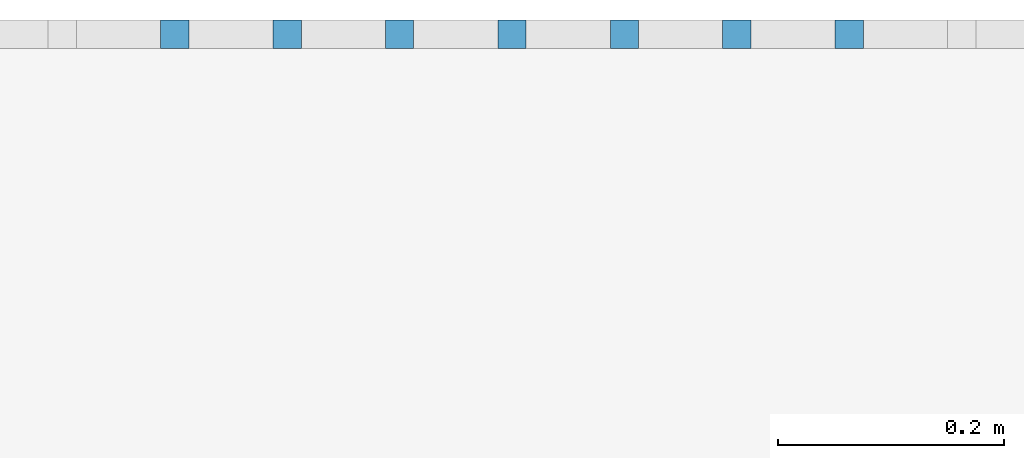
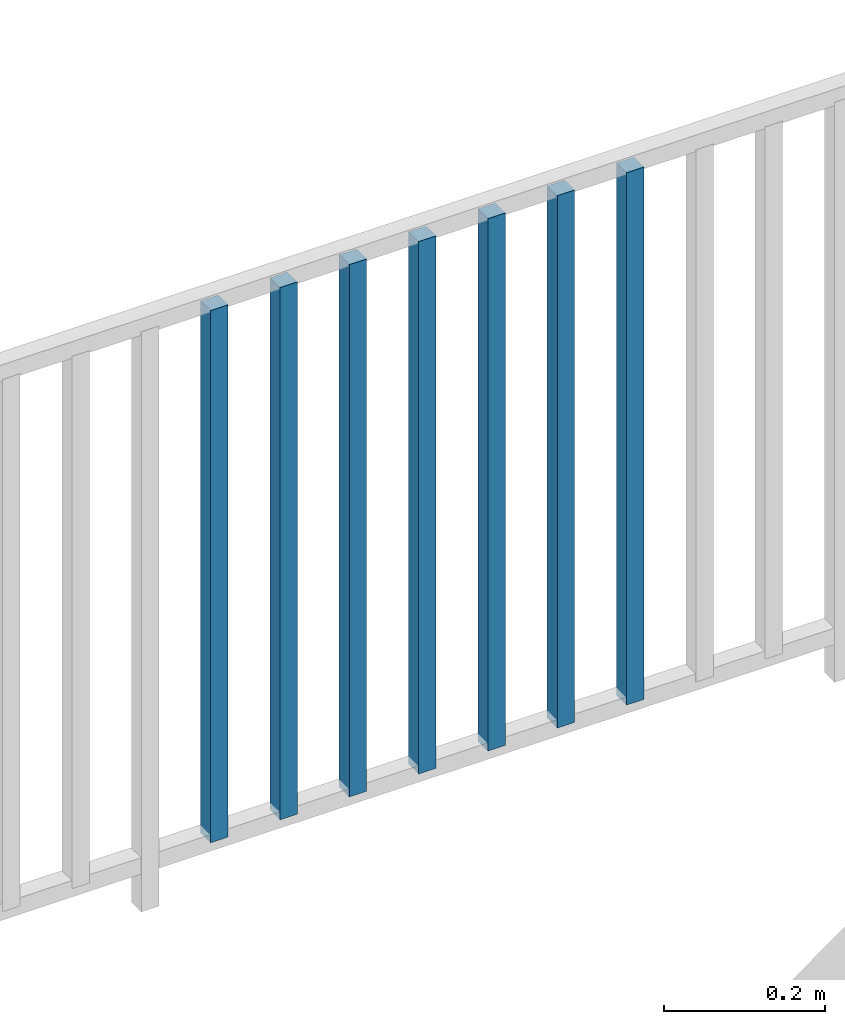
# One storey, part 45 of 48: 7 building element parts, 1 element without a shape of its own.
"""IFC4 building model written with IfcOpenShell, lengths in metres."""

from ifc_helpers import new_model, entity, si_unit, converted_unit, derived_unit, direction, frame, origin_with_axes, place, context, subcontext, project, spatial, polygons, material, type_object, element, aggregate, save


model = new_model("IFC4")

# Units and contexts
model_context = context("Model", 3, precision=1e-05, world=origin_with_axes(), true_north=direction((0.0, 1.0)))
body_context = subcontext(model_context, "Body", "Model", "MODEL_VIEW")
ifc_project = project(units=[si_unit("LENGTHUNIT", "METRE"), si_unit("AREAUNIT", "SQUARE_METRE"), si_unit("VOLUMEUNIT", "CUBIC_METRE"), converted_unit("PLANEANGLEUNIT", "DEGREE", entity("IfcPlaneAngleMeasure", 0.0174532925199), si_unit("PLANEANGLEUNIT", "RADIAN"), dimensions=[0, 0, 0, 0, 0, 0, 0]), converted_unit("TIMEUNIT", "Year", entity("IfcTimeMeasure", 31556926.0), si_unit("TIMEUNIT", "SECOND"), dimensions=[0, 0, 1, 0, 0, 0, 0]), si_unit("MASSUNIT", "GRAM", prefix="KILO"), si_unit("THERMODYNAMICTEMPERATUREUNIT", "DEGREE_CELSIUS"), si_unit("LUMINOUSINTENSITYUNIT", "LUMEN"), si_unit("ENERGYUNIT", "JOULE", prefix="MEGA"), derived_unit("THERMALCONDUCTANCEUNIT", [(si_unit("POWERUNIT", "WATT"), 1), (si_unit("LENGTHUNIT", "METRE"), -1), (si_unit("THERMODYNAMICTEMPERATUREUNIT", "KELVIN"), -1)]), derived_unit("SPECIFICHEATCAPACITYUNIT", [(si_unit("ENERGYUNIT", "JOULE"), 1), (si_unit("MASSUNIT", "GRAM", prefix="KILO"), -1), (si_unit("THERMODYNAMICTEMPERATUREUNIT", "KELVIN"), -1)]), derived_unit("MASSDENSITYUNIT", [(si_unit("MASSUNIT", "GRAM", prefix="KILO"), 1), (si_unit("VOLUMEUNIT", "CUBIC_METRE"), -1)])], contexts=[model_context])

# Site, building, storey
site_placement = place(None, origin_with_axes())
site = spatial("IfcSite", under=ifc_project, at=site_placement, CompositionType="ELEMENT")
building_placement = place(site_placement, origin_with_axes())
building = spatial("IfcBuilding", under=site, at=building_placement, CompositionType="ELEMENT")
storey_placement = place(building_placement, frame((0.0, 0.0, 3.4), z_axis=(0.0, 0.0, 1.0), x_axis=(1.0, 0.0, 0.0)))
storey = spatial("IfcBuildingStorey", under=building, at=storey_placement, Name="1. Geschoss", CompositionType="ELEMENT", Elevation=3.4)

# Railing, building element parts
railing_type = type_object("IfcRailingType", PredefinedType="NOTDEFINED")
railing_placement = place(storey_placement, frame((10.2378006196, 9.82118776896, 0.0), z_axis=(0.0, 0.0, 1.0), x_axis=(1.0, 0.0, 0.0)))
railing = element("IfcRailing", 1, at=railing_placement, inside=storey, type_object=railing_type, PredefinedType="NOTDEFINED")
ifc_material = material()
building_element_part_1_placement = place(railing_placement, origin_with_axes())
building_element_part_1 = element("IfcBuildingElementPart", 2, at=building_element_part_1_placement, material=ifc_material, PredefinedType="NOTDEFINED", context=body_context, shape_type="Tessellation", body=[
    polygons([(-7.27441304348, 0.0125, 0.07), (-7.27441304348, -0.0125, 0.07), (-7.27441304348, -0.0125, 0.8775), (-7.27441304348, 0.0125, 0.8775), (-7.24941304348, 0.0125, 0.07), (-7.24941304348, -0.0125, 0.07), (-7.24941304348, -0.0125, 0.8775), (-7.24941304348, 0.0125, 0.8775)], [[[1, 2, 3, 4]], [[1, 5, 6, 2]], [[2, 6, 7, 3]], [[4, 3, 7, 8]], [[5, 1, 4, 8]], [[6, 5, 8, 7]]], closed=True),
])
building_element_part_2_placement = place(railing_placement, origin_with_axes())
building_element_part_2 = element("IfcBuildingElementPart", 3, at=building_element_part_2_placement, material=ifc_material, PredefinedType="NOTDEFINED", context=body_context, shape_type="Tessellation", body=[
    polygons([(-7.37389130435, 0.0125, 0.07), (-7.37389130435, -0.0125, 0.07), (-7.37389130435, -0.0125, 0.8775), (-7.37389130435, 0.0125, 0.8775), (-7.34889130435, 0.0125, 0.07), (-7.34889130435, -0.0125, 0.07), (-7.34889130435, -0.0125, 0.8775), (-7.34889130435, 0.0125, 0.8775)], [[[1, 2, 3, 4]], [[1, 5, 6, 2]], [[2, 6, 7, 3]], [[4, 3, 7, 8]], [[5, 1, 4, 8]], [[6, 5, 8, 7]]], closed=True),
])
building_element_part_3_placement = place(railing_placement, origin_with_axes())
building_element_part_3 = element("IfcBuildingElementPart", 4, at=building_element_part_3_placement, material=ifc_material, PredefinedType="NOTDEFINED", context=body_context, shape_type="Tessellation", body=[
    polygons([(-7.47336956522, 0.0125, 0.07), (-7.47336956522, -0.0125, 0.07), (-7.47336956522, -0.0125, 0.8775), (-7.47336956522, 0.0125, 0.8775), (-7.44836956522, 0.0125, 0.07), (-7.44836956522, -0.0125, 0.07), (-7.44836956522, -0.0125, 0.8775), (-7.44836956522, 0.0125, 0.8775)], [[[1, 2, 3, 4]], [[1, 5, 6, 2]], [[2, 6, 7, 3]], [[4, 3, 7, 8]], [[5, 1, 4, 8]], [[6, 5, 8, 7]]], closed=True),
])
building_element_part_4_placement = place(railing_placement, origin_with_axes())
building_element_part_4 = element("IfcBuildingElementPart", 5, at=building_element_part_4_placement, material=ifc_material, PredefinedType="NOTDEFINED", context=body_context, shape_type="Tessellation", body=[
    polygons([(-7.57284782609, 0.0125, 0.07), (-7.57284782609, -0.0125, 0.07), (-7.57284782609, -0.0125, 0.8775), (-7.57284782609, 0.0125, 0.8775), (-7.54784782609, 0.0125, 0.07), (-7.54784782609, -0.0125, 0.07), (-7.54784782609, -0.0125, 0.8775), (-7.54784782609, 0.0125, 0.8775)], [[[1, 2, 3, 4]], [[1, 5, 6, 2]], [[2, 6, 7, 3]], [[4, 3, 7, 8]], [[5, 1, 4, 8]], [[6, 5, 8, 7]]], closed=True),
])
building_element_part_5_placement = place(railing_placement, origin_with_axes())
building_element_part_5 = element("IfcBuildingElementPart", 6, at=building_element_part_5_placement, material=ifc_material, PredefinedType="NOTDEFINED", context=body_context, shape_type="Tessellation", body=[
    polygons([(-7.67232608696, 0.0125, 0.07), (-7.67232608696, -0.0125, 0.07), (-7.67232608696, -0.0125, 0.8775), (-7.67232608696, 0.0125, 0.8775), (-7.64732608696, 0.0125, 0.07), (-7.64732608696, -0.0125, 0.07), (-7.64732608696, -0.0125, 0.8775), (-7.64732608696, 0.0125, 0.8775)], [[[1, 2, 3, 4]], [[1, 5, 6, 2]], [[2, 6, 7, 3]], [[4, 3, 7, 8]], [[5, 1, 4, 8]], [[6, 5, 8, 7]]], closed=True),
])
building_element_part_6_placement = place(railing_placement, origin_with_axes())
building_element_part_6 = element("IfcBuildingElementPart", 7, at=building_element_part_6_placement, material=ifc_material, PredefinedType="NOTDEFINED", context=body_context, shape_type="Tessellation", body=[
    polygons([(-7.77180434783, 0.0125, 0.07), (-7.77180434783, -0.0125, 0.07), (-7.77180434783, -0.0125, 0.8775), (-7.77180434783, 0.0125, 0.8775), (-7.74680434783, 0.0125, 0.07), (-7.74680434783, -0.0125, 0.07), (-7.74680434783, -0.0125, 0.8775), (-7.74680434783, 0.0125, 0.8775)], [[[1, 2, 3, 4]], [[1, 5, 6, 2]], [[2, 6, 7, 3]], [[4, 3, 7, 8]], [[5, 1, 4, 8]], [[6, 5, 8, 7]]], closed=True),
])
building_element_part_7_placement = place(railing_placement, origin_with_axes())
building_element_part_7 = element("IfcBuildingElementPart", 8, at=building_element_part_7_placement, material=ifc_material, PredefinedType="NOTDEFINED", context=body_context, shape_type="Tessellation", body=[
    polygons([(-7.8712826087, 0.0125, 0.07), (-7.8712826087, -0.0125, 0.07), (-7.8712826087, -0.0125, 0.8775), (-7.8712826087, 0.0125, 0.8775), (-7.8462826087, 0.0125, 0.07), (-7.8462826087, -0.0125, 0.07), (-7.8462826087, -0.0125, 0.8775), (-7.8462826087, 0.0125, 0.8775)], [[[1, 2, 3, 4]], [[1, 5, 6, 2]], [[2, 6, 7, 3]], [[4, 3, 7, 8]], [[5, 1, 4, 8]], [[6, 5, 8, 7]]], closed=True),
])
aggregate(railing, [building_element_part_1, building_element_part_2, building_element_part_3, building_element_part_4, building_element_part_5, building_element_part_6, building_element_part_7])

save(model, "model.ifc")
